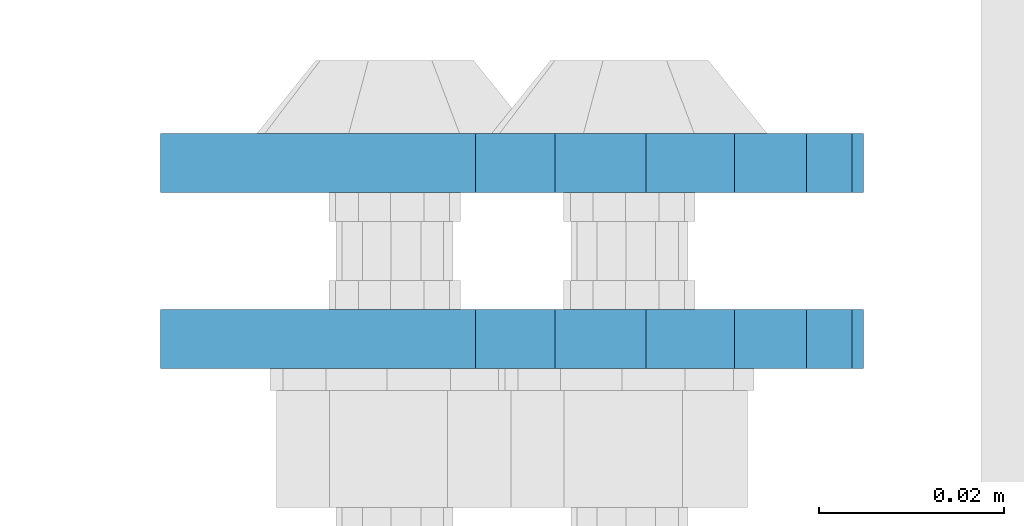
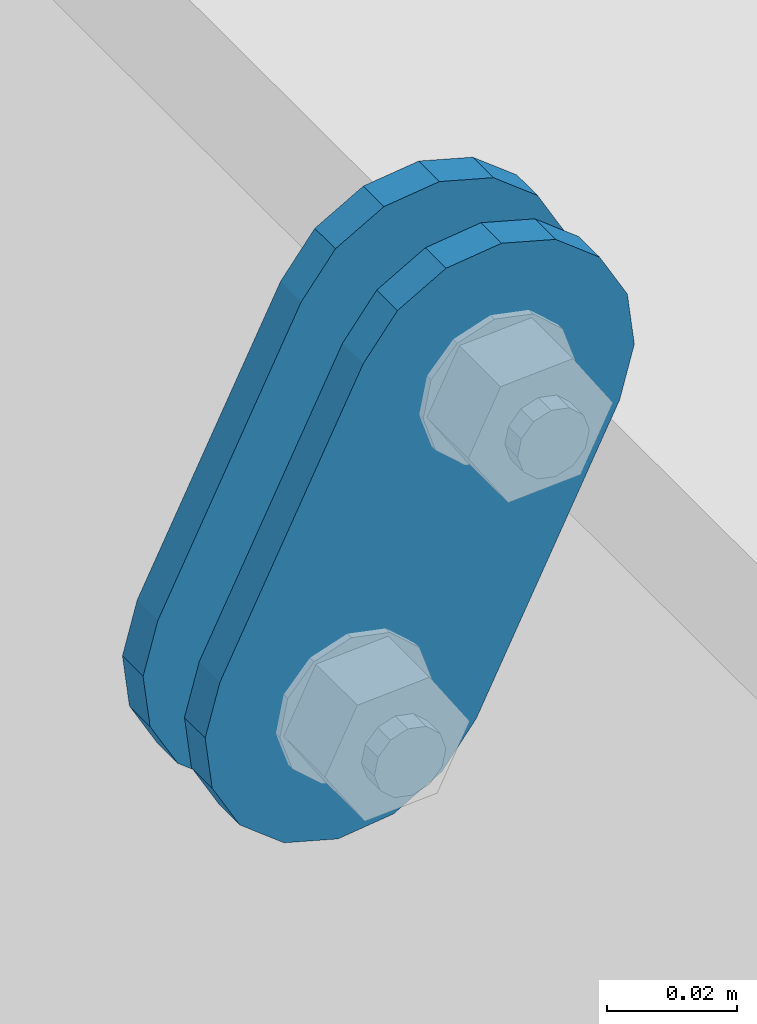
# One storey, part 1532 of 1876: 2 plates, 2 elements without a shape of their own.
"""IFC2X3 building model written with IfcOpenShell, lengths in millimetres."""

from ifc_helpers import new_model, si_unit, frame, origin_with_axes, place, context, subcontext, project, spatial, faceted_brep, material, type_object, element, aggregate, save


model = new_model("IFC2X3")

# Units and contexts
model_context = context("Model", 3, precision=1e-05, world=origin_with_axes())
body_context = subcontext(model_context, "Body", "Model", "MODEL_VIEW")
ifc_project = project(units=[si_unit("LENGTHUNIT", "METRE", prefix="MILLI"), si_unit("AREAUNIT", "SQUARE_METRE"), si_unit("VOLUMEUNIT", "CUBIC_METRE"), si_unit("MASSUNIT", "GRAM", prefix="KILO"), si_unit("TIMEUNIT", "SECOND"), si_unit("PLANEANGLEUNIT", "RADIAN"), si_unit("SOLIDANGLEUNIT", "STERADIAN"), si_unit("THERMODYNAMICTEMPERATUREUNIT", "DEGREE_CELSIUS"), si_unit("LUMINOUSINTENSITYUNIT", "LUMEN")], contexts=[model_context])

# Site, building, storey
site_placement = place(None, origin_with_axes())
site = spatial("IfcSite", under=ifc_project, at=site_placement, CompositionType="ELEMENT")
building_placement = place(site_placement, origin_with_axes())
building = spatial("IfcBuilding", under=site, at=building_placement, Name="Undefined", CompositionType="ELEMENT")
storey_placement = place(building_placement, origin_with_axes())
storey = spatial("IfcBuildingStorey", under=building, at=storey_placement, Name="Undefined", CompositionType="ELEMENT", Elevation=0.0)

# Assembly, plate
assembly_1_placement = place(storey_placement, origin_with_axes())
assembly_1 = element("IfcElementAssembly", 1, at=assembly_1_placement, inside=storey, Name="PLATE", AssemblyPlace="NOTDEFINED", PredefinedType="RIGID_FRAME")
ifc_material = material(Name="STEEL/A36")
plate_type = type_object("IfcPlateType", PredefinedType="NOTDEFINED")
plate_1_placement = place(assembly_1_placement, frame((-354.259224851122, -517.524994679405, 7895.37767748094), z_axis=(0.894427191199916, 0.0, -0.447213595099958), x_axis=(-0.447213595099961, 6.99999707257306e-09, -0.894427191199915)))
plate_1 = element("IfcPlate", 2, at=plate_1_placement, type_object=plate_type, material=ifc_material, Name="PLATE", context=body_context, shape_type="Brep", body=[
    faceted_brep([(-8.59611645864788e-07, -3.17499999999654, 25.3999987589127), (1.93345873884391, -3.17499999999382, 35.1201580589886), (1.93345873884391, 3.17500000000564, 35.1201580589886), (-8.59611645864788e-07, 3.17500000000382, 25.3999987589132), (7.43948648259902, -3.17499999999109, 43.3605112870105), (7.43948648259902, 3.17500000000928, 43.3605112870105), (15.6798395242777, -3.17499999998654, 48.8665393096448), (15.6798395242777, 3.17500000001382, 48.8665393096448), (25.3999987589095, -3.17499999998199, 50.7999992370592), (25.3999987589095, 3.17500000001837, 50.7999992370592), (82.196130752618, -3.17499999998381, 50.7999992370605), (82.196130752618, 3.17500000001655, 50.7999992370642), (91.9162897887145, -3.17499999997926, 48.8665393918873), (91.9162897887145, 3.1750000000211, 48.8665393918909), (100.156642725027, -3.17499999997472, 43.3605115909359), (100.156642725027, 3.17500000002565, 43.3605115909395), (105.662670525982, -3.17499999997108, 35.1201586546285), (105.662670525986, 3.17500000002929, 35.1201586546358), (107.596130371159, -3.17499999996744, 25.3999996185757), (107.596130371159, 3.17500000003292, 25.3999996185794), (105.662670525981, -3.17499999996471, 15.6798405824902), (105.662670525981, 3.17500000003565, 15.6798405824939), (100.156642725024, -3.17499999996471, 7.43948764618654), (100.156642725025, 3.17500000003565, 7.43948764619017), (91.9162897887127, -3.17499999996562, 1.93345984522784), (91.9162897887127, 3.17500000003474, 1.93345984523148), (82.196130752618, -3.17499999996835, 4.54747350886464e-11), (82.196130752618, 3.1750000000311, 4.91127138957381e-11), (25.399998758905, -3.17499999999018, -8.64019966684282e-12), (25.399998758905, 3.17500000001019, -8.64019966684282e-12), (15.679839921364, -3.17499999999382, 1.9334597629304), (15.679839921364, 3.17500000000655, 1.9334597629304), (7.43948709043525, -3.17499999999654, 7.43948734220839), (7.43948709043525, 3.17500000000382, 7.43948734220885), (1.93345923228208, -3.17499999999654, 15.6798399868012), (1.93345923228208, 3.17500000000291, 15.6798399868012)], [[[0, 1, 2, 3]], [[1, 4, 5, 2]], [[4, 6, 7, 5]], [[6, 8, 9, 7]], [[8, 10, 11, 9]], [[10, 12, 13, 11]], [[12, 14, 15, 13]], [[14, 16, 17, 15]], [[16, 18, 19, 17]], [[18, 20, 21, 19]], [[20, 22, 23, 21]], [[22, 24, 25, 23]], [[24, 26, 27, 25]], [[26, 28, 29, 27]], [[28, 30, 31, 29]], [[30, 32, 33, 31]], [[32, 34, 35, 33]], [[34, 0, 3, 35]], [[5, 7, 9, 11, 13, 15, 17, 19, 21, 23, 25, 27, 29, 31, 33, 35, 3, 2]], [[34, 32, 30, 28, 26, 24, 22, 20, 18, 16, 14, 12, 10, 8, 6, 4, 1, 0]]]),
])
aggregate(assembly_1, [plate_1])

assembly_2_placement = place(storey_placement, origin_with_axes())
assembly_2 = element("IfcElementAssembly", 3, at=assembly_2_placement, inside=storey, Name="PLATE", AssemblyPlace="NOTDEFINED", PredefinedType="RIGID_FRAME")
plate_2_placement = place(assembly_2_placement, frame((-354.259224851122, -498.463798374725, 7895.37767748094), z_axis=(0.894427191199916, 0.0, -0.447213595099958), x_axis=(-0.447213595099961, 6.99999707257306e-09, -0.894427191199915)))
plate_2 = element("IfcPlate", 4, at=plate_2_placement, type_object=plate_type, material=ifc_material, Name="PLATE", context=body_context, shape_type="Brep", body=[
    faceted_brep([(-8.59611645864788e-07, -3.17499999999654, 25.3999987589127), (1.93345873884391, -3.17499999999382, 35.1201580589886), (1.93345873884391, 3.17500000000564, 35.1201580589886), (-8.59611645864788e-07, 3.17500000000382, 25.3999987589132), (7.43948648259902, -3.17499999999109, 43.3605112870105), (7.43948648259902, 3.17500000000928, 43.3605112870105), (15.6798395242777, -3.17499999998654, 48.8665393096448), (15.6798395242777, 3.17500000001382, 48.8665393096448), (25.3999987589095, -3.17499999998199, 50.7999992370592), (25.3999987589095, 3.17500000001837, 50.7999992370592), (82.196130752618, -3.17499999998381, 50.7999992370605), (82.196130752618, 3.17500000001655, 50.7999992370642), (91.9162897887145, -3.17499999997926, 48.8665393918873), (91.9162897887145, 3.1750000000211, 48.8665393918909), (100.156642725027, -3.17499999997472, 43.3605115909359), (100.156642725027, 3.17500000002565, 43.3605115909395), (105.662670525982, -3.17499999997108, 35.1201586546285), (105.662670525986, 3.17500000002929, 35.1201586546358), (107.596130371159, -3.17499999996744, 25.3999996185757), (107.596130371159, 3.17500000003292, 25.3999996185794), (105.662670525981, -3.17499999996471, 15.6798405824902), (105.662670525981, 3.17500000003565, 15.6798405824939), (100.156642725024, -3.17499999996471, 7.43948764618654), (100.156642725025, 3.17500000003565, 7.43948764619017), (91.9162897887127, -3.17499999996562, 1.93345984522784), (91.9162897887127, 3.17500000003474, 1.93345984523148), (82.196130752618, -3.17499999996835, 4.54747350886464e-11), (82.196130752618, 3.1750000000311, 4.91127138957381e-11), (25.399998758905, -3.17499999999018, -8.64019966684282e-12), (25.399998758905, 3.17500000001019, -8.64019966684282e-12), (15.679839921364, -3.17499999999382, 1.9334597629304), (15.679839921364, 3.17500000000655, 1.9334597629304), (7.43948709043525, -3.17499999999654, 7.43948734220839), (7.43948709043525, 3.17500000000382, 7.43948734220885), (1.93345923228208, -3.17499999999654, 15.6798399868012), (1.93345923228208, 3.17500000000291, 15.6798399868012)], [[[0, 1, 2, 3]], [[1, 4, 5, 2]], [[4, 6, 7, 5]], [[6, 8, 9, 7]], [[8, 10, 11, 9]], [[10, 12, 13, 11]], [[12, 14, 15, 13]], [[14, 16, 17, 15]], [[16, 18, 19, 17]], [[18, 20, 21, 19]], [[20, 22, 23, 21]], [[22, 24, 25, 23]], [[24, 26, 27, 25]], [[26, 28, 29, 27]], [[28, 30, 31, 29]], [[30, 32, 33, 31]], [[32, 34, 35, 33]], [[34, 0, 3, 35]], [[5, 7, 9, 11, 13, 15, 17, 19, 21, 23, 25, 27, 29, 31, 33, 35, 3, 2]], [[34, 32, 30, 28, 26, 24, 22, 20, 18, 16, 14, 12, 10, 8, 6, 4, 1, 0]]]),
])
aggregate(assembly_2, [plate_2])

save(model, "model.ifc")
